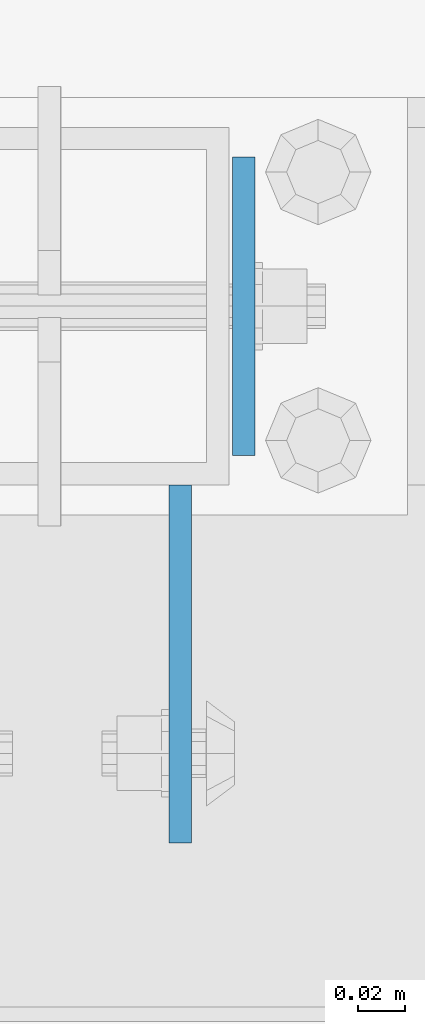
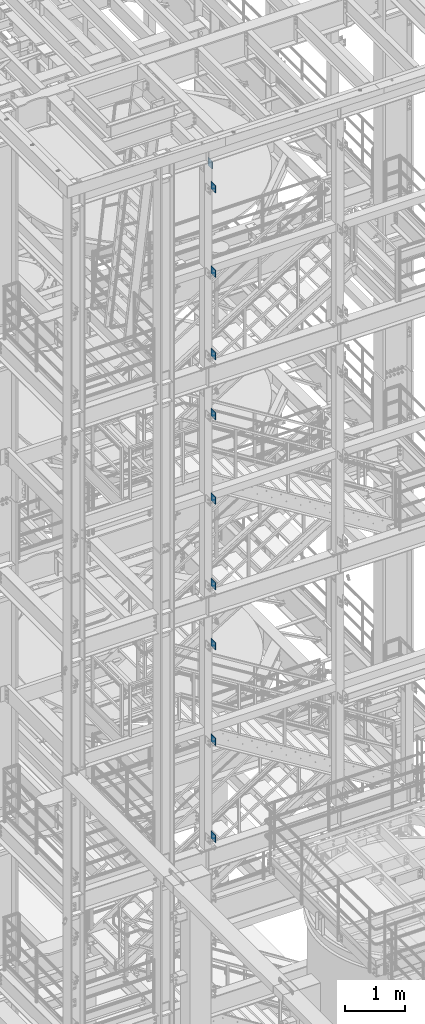
# One storey, part 1132 of 1876: 10 beams, 4 elements without a shape of their own.
"""IFC2X3 building model written with IfcOpenShell, lengths in millimetres."""

from ifc_helpers import new_model, si_unit, frame, origin_with_axes, place, context, subcontext, project, spatial, faceted_brep, material, type_object, element, aggregate, save


model = new_model("IFC2X3")

# Units and contexts
model_context = context("Model", 3, precision=1e-05, world=origin_with_axes())
body_context = subcontext(model_context, "Body", "Model", "MODEL_VIEW")
ifc_project = project(units=[si_unit("LENGTHUNIT", "METRE", prefix="MILLI"), si_unit("AREAUNIT", "SQUARE_METRE"), si_unit("VOLUMEUNIT", "CUBIC_METRE"), si_unit("MASSUNIT", "GRAM", prefix="KILO"), si_unit("TIMEUNIT", "SECOND"), si_unit("PLANEANGLEUNIT", "RADIAN"), si_unit("SOLIDANGLEUNIT", "STERADIAN"), si_unit("THERMODYNAMICTEMPERATUREUNIT", "DEGREE_CELSIUS"), si_unit("LUMINOUSINTENSITYUNIT", "LUMEN")], contexts=[model_context])

# Site, building, storey
site_placement = place(None, origin_with_axes())
site = spatial("IfcSite", under=ifc_project, at=site_placement, CompositionType="ELEMENT")
building_placement = place(site_placement, origin_with_axes())
building = spatial("IfcBuilding", under=site, at=building_placement, Name="Undefined", CompositionType="ELEMENT")
storey_placement = place(building_placement, origin_with_axes())
storey = spatial("IfcBuildingStorey", under=building, at=storey_placement, Name="Undefined", CompositionType="ELEMENT", Elevation=0.0)

# Assembly, beams
assembly_1_placement = place(storey_placement, origin_with_axes())
assembly_1 = element("IfcElementAssembly", 1, at=assembly_1_placement, inside=storey, Name="FRAME", AssemblyPlace="NOTDEFINED", PredefinedType="RIGID_FRAME")
ifc_material = material(Name="STEEL/A36")
beam_type_1 = type_object("IfcBeamType", PredefinedType="NOTDEFINED")
beam_1_placement = place(assembly_1_placement, frame((2595.5512944527, -7188.2, 21678.9), z_axis=(0.0, 0.0, -1.0), x_axis=(0.0, -1.0, 0.0)))
beam_1 = element("IfcBeam", 2, at=beam_1_placement, type_object=beam_type_1, material=ifc_material, Name="PLATE", context=body_context, shape_type="Brep", body=[
    faceted_brep([(0.0, 4.76249999999982, -76.1999999999998), (3.63797880709171e-12, 4.76249999999982, 76.1999969482422), (152.399993896484, 4.76250000000073, 76.1999969482422), (152.4, 4.76249999999982, -76.1999999999998), (3.63797880709171e-12, -4.76249999999982, 76.1999969482422), (152.399993896484, -4.76250000000073, 76.1999969482422), (0.0, -4.76249999999982, -76.1999999999998), (152.4, -4.76249999999982, -76.1999999999998)], [[[0, 1, 2, 3]], [[4, 5, 2, 1]], [[4, 6, 7, 5]], [[6, 0, 3, 7]], [[5, 7, 3, 2]], [[6, 4, 1, 0]]]),
])
beam_2_placement = place(assembly_1_placement, frame((2595.5512944527, -7188.2, 19958.05), z_axis=(0.0, 0.0, -1.0), x_axis=(0.0, -1.0, 0.0)))
beam_2 = element("IfcBeam", 3, at=beam_2_placement, type_object=beam_type_1, material=ifc_material, Name="PLATE", context=body_context, shape_type="Brep", body=[
    faceted_brep([(0.0, 4.76249999999982, -76.1999999999998), (3.63797880709171e-12, 4.76249999999982, 76.1999969482422), (152.399993896484, 4.76250000000073, 76.1999969482422), (152.4, 4.76249999999982, -76.1999999999998), (3.63797880709171e-12, -4.76249999999982, 76.1999969482422), (152.399993896484, -4.76250000000073, 76.1999969482422), (0.0, -4.76249999999982, -76.1999999999998), (152.4, -4.76249999999982, -76.1999999999998)], [[[0, 1, 2, 3]], [[4, 5, 2, 1]], [[4, 6, 7, 5]], [[6, 0, 3, 7]], [[5, 7, 3, 2]], [[6, 4, 1, 0]]]),
])
beam_3_placement = place(assembly_1_placement, frame((2595.5512944527, -7188.2, 18275.3), z_axis=(0.0, 0.0, -1.0), x_axis=(0.0, -1.0, 0.0)))
beam_3 = element("IfcBeam", 4, at=beam_3_placement, type_object=beam_type_1, material=ifc_material, Name="PLATE", context=body_context, shape_type="Brep", body=[
    faceted_brep([(0.0, 4.76249999999982, -76.1999999999998), (3.63797880709171e-12, 4.76249999999982, 76.1999969482422), (152.399993896484, 4.76250000000073, 76.1999969482422), (152.4, 4.76249999999982, -76.1999999999998), (3.63797880709171e-12, -4.76249999999982, 76.1999969482422), (152.399993896484, -4.76250000000073, 76.1999969482422), (0.0, -4.76249999999982, -76.1999999999998), (152.4, -4.76249999999982, -76.1999999999998)], [[[0, 1, 2, 3]], [[4, 5, 2, 1]], [[4, 6, 7, 5]], [[6, 0, 3, 7]], [[5, 7, 3, 2]], [[6, 4, 1, 0]]]),
])
aggregate(assembly_1, [beam_1, beam_2, beam_3])

assembly_2_placement = place(storey_placement, origin_with_axes())
assembly_2 = element("IfcElementAssembly", 5, at=assembly_2_placement, inside=storey, Name="FRAME", AssemblyPlace="NOTDEFINED", PredefinedType="RIGID_FRAME")
beam_4_placement = place(assembly_2_placement, frame((2595.5512944527, -7188.2, 17056.1), z_axis=(0.0, 0.0, -1.0), x_axis=(0.0, -1.0, 0.0)))
beam_4 = element("IfcBeam", 6, at=beam_4_placement, type_object=beam_type_1, material=ifc_material, Name="PLATE", context=body_context, shape_type="Brep", body=[
    faceted_brep([(0.0, 4.76249999999982, -76.1999999999998), (3.63797880709171e-12, 4.76249999999982, 76.1999969482422), (152.399993896484, 4.76250000000073, 76.1999969482422), (152.4, 4.76249999999982, -76.1999999999998), (3.63797880709171e-12, -4.76249999999982, 76.1999969482422), (152.399993896484, -4.76250000000073, 76.1999969482422), (0.0, -4.76249999999982, -76.1999999999998), (152.4, -4.76249999999982, -76.1999999999998)], [[[0, 1, 2, 3]], [[4, 5, 2, 1]], [[4, 6, 7, 5]], [[6, 0, 3, 7]], [[5, 7, 3, 2]], [[6, 4, 1, 0]]]),
])
beam_5_placement = place(assembly_2_placement, frame((2595.5512944527, -7188.2, 15335.25), z_axis=(0.0, 0.0, -1.0), x_axis=(0.0, -1.0, 0.0)))
beam_5 = element("IfcBeam", 7, at=beam_5_placement, type_object=beam_type_1, material=ifc_material, Name="PLATE", context=body_context, shape_type="Brep", body=[
    faceted_brep([(0.0, 4.76249999999982, -76.1999999999998), (3.63797880709171e-12, 4.76249999999982, 76.1999969482422), (152.399993896484, 4.76250000000073, 76.1999969482422), (152.4, 4.76249999999982, -76.1999999999998), (3.63797880709171e-12, -4.76249999999982, 76.1999969482422), (152.399993896484, -4.76250000000073, 76.1999969482422), (0.0, -4.76249999999982, -76.1999999999998), (152.4, -4.76249999999982, -76.1999999999998)], [[[0, 1, 2, 3]], [[4, 5, 2, 1]], [[4, 6, 7, 5]], [[6, 0, 3, 7]], [[5, 7, 3, 2]], [[6, 4, 1, 0]]]),
])
beam_6_placement = place(assembly_2_placement, frame((2595.5512944527, -7188.2, 13589.0), z_axis=(0.0, 0.0, -1.0), x_axis=(0.0, -1.0, 0.0)))
beam_6 = element("IfcBeam", 8, at=beam_6_placement, type_object=beam_type_1, material=ifc_material, Name="PLATE", context=body_context, shape_type="Brep", body=[
    faceted_brep([(0.0, 4.76249999999982, -76.1999999999998), (3.63797880709171e-12, 4.76249999999982, 76.1999969482422), (152.399993896484, 4.76250000000073, 76.1999969482422), (152.4, 4.76249999999982, -76.1999999999998), (3.63797880709171e-12, -4.76249999999982, 76.1999969482422), (152.399993896484, -4.76250000000073, 76.1999969482422), (0.0, -4.76249999999982, -76.1999999999998), (152.4, -4.76249999999982, -76.1999999999998)], [[[0, 1, 2, 3]], [[4, 5, 2, 1]], [[4, 6, 7, 5]], [[6, 0, 3, 7]], [[5, 7, 3, 2]], [[6, 4, 1, 0]]]),
])
aggregate(assembly_2, [beam_4, beam_5, beam_6])

assembly_3_placement = place(storey_placement, origin_with_axes())
assembly_3 = element("IfcElementAssembly", 9, at=assembly_3_placement, inside=storey, Name="FRAME", AssemblyPlace="NOTDEFINED", PredefinedType="RIGID_FRAME")
beam_7_placement = place(assembly_3_placement, frame((2595.5512944527, -7188.2, 12369.8), z_axis=(0.0, 0.0, -1.0), x_axis=(0.0, -1.0, 0.0)))
beam_7 = element("IfcBeam", 10, at=beam_7_placement, type_object=beam_type_1, material=ifc_material, Name="PLATE", context=body_context, shape_type="Brep", body=[
    faceted_brep([(0.0, 4.76249999999982, -76.1999999999998), (3.63797880709171e-12, 4.76249999999982, 76.1999969482422), (152.399993896484, 4.76250000000073, 76.1999969482422), (152.4, 4.76249999999982, -76.1999999999998), (3.63797880709171e-12, -4.76249999999982, 76.1999969482422), (152.399993896484, -4.76250000000073, 76.1999969482422), (0.0, -4.76249999999982, -76.1999999999998), (152.4, -4.76249999999982, -76.1999999999998)], [[[0, 1, 2, 3]], [[4, 5, 2, 1]], [[4, 6, 7, 5]], [[6, 0, 3, 7]], [[5, 7, 3, 2]], [[6, 4, 1, 0]]]),
])
beam_8_placement = place(assembly_3_placement, frame((2595.5512944527, -7188.2, 10420.35), z_axis=(0.0, 0.0, -1.0), x_axis=(0.0, -1.0, 0.0)))
beam_8 = element("IfcBeam", 11, at=beam_8_placement, type_object=beam_type_1, material=ifc_material, Name="PLATE", context=body_context, shape_type="Brep", body=[
    faceted_brep([(0.0, 4.76249999999982, -76.1999999999998), (3.63797880709171e-12, 4.76249999999982, 76.1999969482422), (152.399993896484, 4.76250000000073, 76.1999969482422), (152.4, 4.76249999999982, -76.1999999999998), (3.63797880709171e-12, -4.76249999999982, 76.1999969482422), (152.399993896484, -4.76250000000073, 76.1999969482422), (0.0, -4.76249999999982, -76.1999999999998), (152.4, -4.76249999999982, -76.1999999999998)], [[[0, 1, 2, 3]], [[4, 5, 2, 1]], [[4, 6, 7, 5]], [[6, 0, 3, 7]], [[5, 7, 3, 2]], [[6, 4, 1, 0]]]),
])
beam_9_placement = place(assembly_3_placement, frame((2595.5512944527, -7188.2, 8445.5), z_axis=(0.0, 0.0, -1.0), x_axis=(0.0, -1.0, 0.0)))
beam_9 = element("IfcBeam", 12, at=beam_9_placement, type_object=beam_type_1, material=ifc_material, Name="PLATE", context=body_context, shape_type="Brep", body=[
    faceted_brep([(0.0, 4.76249999999982, -76.1999999999998), (3.63797880709171e-12, 4.76249999999982, 76.1999969482422), (152.399993896484, 4.76250000000073, 76.1999969482422), (152.4, 4.76249999999982, -76.1999999999998), (3.63797880709171e-12, -4.76249999999982, 76.1999969482422), (152.399993896484, -4.76250000000073, 76.1999969482422), (0.0, -4.76249999999982, -76.1999999999998), (152.4, -4.76249999999982, -76.1999999999998)], [[[0, 1, 2, 3]], [[4, 5, 2, 1]], [[4, 6, 7, 5]], [[6, 0, 3, 7]], [[5, 7, 3, 2]], [[6, 4, 1, 0]]]),
])
aggregate(assembly_3, [beam_7, beam_8, beam_9])

# Assembly, beam
assembly_4_placement = place(storey_placement, origin_with_axes())
assembly_4 = element("IfcElementAssembly", 13, at=assembly_4_placement, inside=storey, Name="BEAM", AssemblyPlace="NOTDEFINED", PredefinedType="RIGID_FRAME")
beam_type_2 = type_object("IfcBeamType", PredefinedType="NOTDEFINED")
beam_10_placement = place(assembly_4_placement, frame((2622.55, -7048.5, 22063.075), z_axis=(0.0, 0.0, -1.0), x_axis=(0.0, -1.0, 0.0)))
beam_10 = element("IfcBeam", 14, at=beam_10_placement, type_object=beam_type_2, material=ifc_material, Name="PLATE", context=body_context, shape_type="Brep", body=[
    faceted_brep([(0.0, 4.76249999999982, -82.5499999999993), (0.0, 4.76249999999982, 82.5499999999993), (127.0, 4.76249999999982, 82.5499999999993), (127.0, 4.76249999999982, -82.5499999999993), (0.0, -4.76249999999982, 82.5499999999993), (127.0, -4.76249999999982, 82.5499999999993), (0.0, -4.76249999999982, -82.5499999999993), (127.0, -4.76249999999982, -82.5499999999993)], [[[0, 1, 2, 3]], [[1, 4, 5, 2]], [[4, 6, 7, 5]], [[6, 0, 3, 7]], [[5, 7, 3, 2]], [[6, 4, 1, 0]]]),
])
aggregate(assembly_4, [beam_10])

save(model, "model.ifc")
